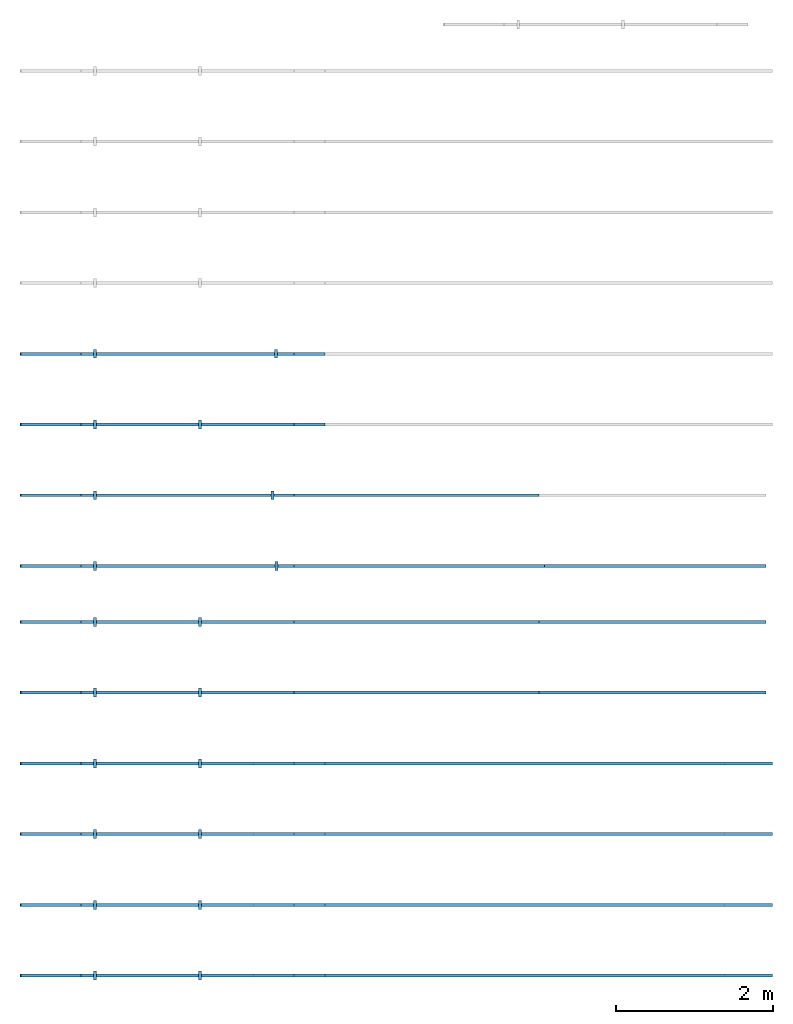
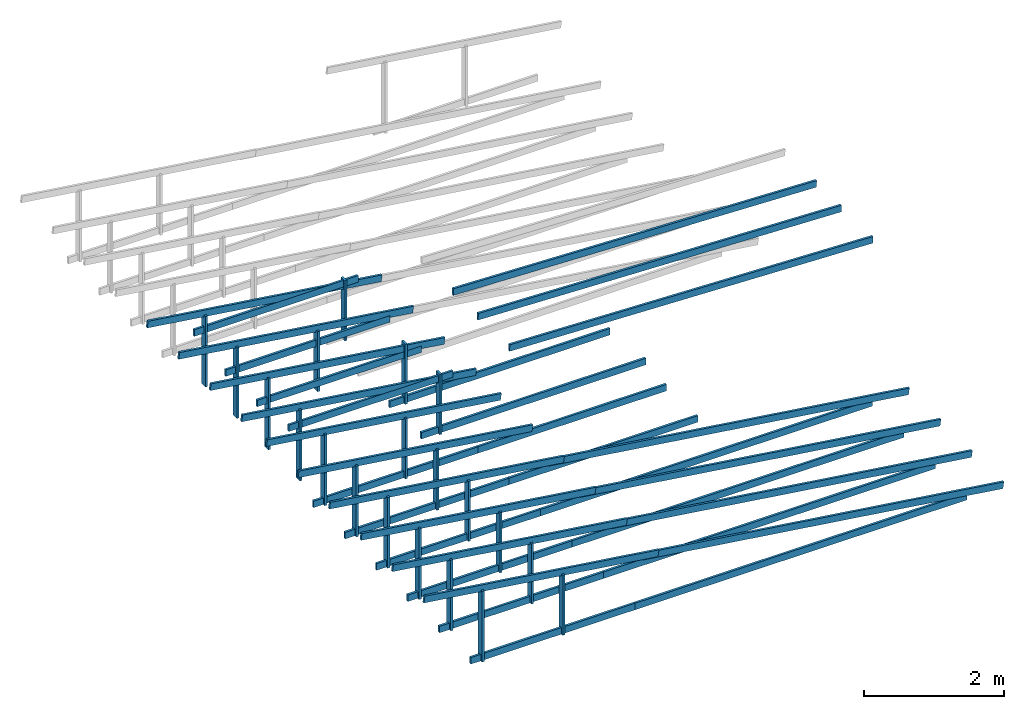
# Not in any storey, part 1 of 2: 55 roofs, 1 element without a shape of its own.
"""IFC4 model written with IfcOpenShell, lengths in millimetres."""

from ifc_helpers import new_model, entity, si_unit, converted_unit, frame, origin_with_axes, origin_2d_with_axis, place, context, subcontext, project, rectangle, extrude, material, material_profile, profile_set, profile_usage, type_object, element, aggregate, save


model = new_model("IFC4")

# Units and contexts
model_context = context("Model", 3, precision=1e-05, world=origin_with_axes())
plan_context = context("Plan", 2, precision=1e-05, world=origin_2d_with_axis())
body_context = subcontext(model_context, "Body", "Model", "MODEL_VIEW")
ifc_project = project(units=[si_unit("VOLUMEUNIT", "CUBIC_METRE"), si_unit("LENGTHUNIT", "METRE", prefix="MILLI"), converted_unit("PLANEANGLEUNIT", "degree", entity("IfcReal", 0.0174532925199433), si_unit("PLANEANGLEUNIT", "RADIAN"), dimensions=[0, 0, 0, 0, 0, 0, 0]), si_unit("AREAUNIT", "SQUARE_METRE")], contexts=[model_context, plan_context])

# Assembly, roofs
assembly_placement = place(None, frame((8638.14163208008, 12731.990814209, 0.0), z_axis=(0.0, 0.0, 1.0), x_axis=(-0.999999999999947, -3.25841369885876e-07, 0.0)))
assembly = element("IfcElementAssembly", 1, at=assembly_placement, Name="Assembly")
ifc_material = material()
ifc_material_profile = material_profile(ifc_material, rectangle(XDim=38.0, YDim=114.0))
ifc_profile_set = profile_set([ifc_material_profile])
ifc_profile_usage_1 = profile_usage(ifc_profile_set, cardinal=5)
roof_type = type_object("IfcRoofType", Name="timber 38x114", PredefinedType="BARREL_ROOF", material=ifc_profile_set)
roof_1_placement = place(assembly_placement, frame((2602.95824585322, 7450.48676552689, 2478.00016403198), z_axis=(0.999999999999919, -3.69552768830747e-07, -1.62920684942944e-07), x_axis=(3.6955275817261e-07, 0.99999999999993, -5.96046376699631e-08)))
roof_1 = element("IfcRoof", 2, at=roof_1_placement, type_object=roof_type, material=ifc_profile_usage_1, Name="Beam.026", PredefinedType="BARREL_ROOF", context=body_context, shape_type="SweptSolid", body=[
    extrude(rectangle(XDim=38.0, YDim=114.0), origin_with_axes(), (0.0, 0.0, 1.0), 3637.04351333381),
])
ifc_profile_usage_2 = profile_usage(ifc_profile_set, cardinal=5)
roof_2_placement = place(assembly_placement, frame((5711.19814191005, 6739.99743333674, 4800.8017539978), z_axis=(-0.999390828302623, -4.9420837146397e-07, -0.034899459943574), x_axis=(4.88762054828645e-07, -0.999999999999867, 1.6459050300449e-07)))
roof_2 = element("IfcRoof", 3, at=roof_2_placement, type_object=roof_type, material=ifc_profile_usage_2, Name="Beam.057", PredefinedType="BARREL_ROOF", context=body_context, shape_type="SweptSolid", body=[
    extrude(rectangle(XDim=38.0, YDim=114.0), origin_with_axes(), (0.0, 0.0, 1.0), 6000.00000000001),
])
ifc_profile_usage_3 = profile_usage(ifc_profile_set, cardinal=5)
roof_3_placement = place(assembly_placement, frame((5719.1305595434, 7450.4862269862, 2478.00016403198), z_axis=(0.999999999999973, 1.62920684942916e-07, -1.62920684942925e-07), x_axis=(-1.62920684942918e-07, 0.999999999999987, 7.1609385088314e-15)))
roof_3 = element("IfcRoof", 4, at=roof_3_placement, type_object=roof_type, material=ifc_profile_usage_3, Name="Beam.063", PredefinedType="BARREL_ROOF", context=body_context, shape_type="SweptSolid", body=[
    extrude(rectangle(XDim=38.0, YDim=114.0), origin_with_axes(), (0.0, 0.0, 1.0), 2709.05258213867),
])
ifc_profile_usage_4 = profile_usage(ifc_profile_set, cardinal=5)
roof_4_placement = place(assembly_placement, frame((8248.028321842, 7450.48587980384, 2420.62544822693), z_axis=(1.05540572307067e-14, 1.20724322982826e-07, 0.999999999999993), x_axis=(-0.999999999999996, 8.74227907843234e-08, -2.09332735654617e-22)))
roof_4 = element("IfcRoof", 5, at=roof_4_placement, type_object=roof_type, material=ifc_profile_usage_4, Name="Beam.085", PredefinedType="BARREL_ROOF", context=body_context, shape_type="SweptSolid", body=[
    extrude(rectangle(XDim=38.0, YDim=114.0), origin_with_axes(), (0.0, 0.0, 1.0), 1234.31299754043),
])
ifc_profile_usage_5 = profile_usage(ifc_profile_set, cardinal=5)
roof_5_placement = place(assembly_placement, frame((5334.54231796627, 7450.48635230096, 3273.04244041443), z_axis=(0.990268086286663, 1.71346197440185e-07, 0.139172976120085), x_axis=(-1.62920684942918e-07, 0.999999999999984, -7.19328738796233e-08)))
roof_5 = element("IfcRoof", 6, at=roof_5_placement, type_object=roof_type, material=ifc_profile_usage_5, Name="Beam.069", PredefinedType="BARREL_ROOF", context=body_context, shape_type="SweptSolid", body=[
    extrude(rectangle(XDim=38.0, YDim=114.0), origin_with_axes(), (0.0, 0.0, 1.0), 3899.99944705231),
])
ifc_profile_usage_6 = profile_usage(ifc_profile_set, cardinal=5)
roof_6_placement = place(assembly_placement, frame((6916.5220695531, 7450.48583682651, 2420.62544822693), z_axis=(1.24156629368653e-14, 1.4201860665253e-07, 0.99999999999999), x_axis=(-0.999999999999996, 8.74227907843234e-08, -7.42746696787314e-22)))
roof_6 = element("IfcRoof", 7, at=roof_6_placement, type_object=roof_type, material=ifc_profile_usage_6, Name="Beam.038", PredefinedType="BARREL_ROOF", context=body_context, shape_type="SweptSolid", body=[
    extrude(rectangle(XDim=38.0, YDim=114.0), origin_with_axes(), (0.0, 0.0, 1.0), 1049.24011663183),
])
ifc_profile_usage_7 = profile_usage(ifc_profile_set, cardinal=5)
roof_7_placement = place(assembly_placement, frame((8248.02861509911, 8350.48549833407, 2420.62544822693), z_axis=(1.05540572307067e-14, 1.20724322982826e-07, 0.999999999999993), x_axis=(-0.999999999999996, 8.74227907843234e-08, -2.09332735654617e-22)))
roof_7 = element("IfcRoof", 8, at=roof_7_placement, type_object=roof_type, material=ifc_profile_usage_7, Name="Beam.017", PredefinedType="BARREL_ROOF", context=body_context, shape_type="SweptSolid", body=[
    extrude(rectangle(XDim=38.0, YDim=114.0), origin_with_axes(), (0.0, 0.0, 1.0), 1234.31299754043),
])
ifc_profile_usage_8 = profile_usage(ifc_profile_set, cardinal=5)
roof_8_placement = place(assembly_placement, frame((2602.95758543601, 8350.48638405743, 2478.00016403198), z_axis=(0.999999999999919, -3.69552768830747e-07, -1.62920684942944e-07), x_axis=(3.6955275817261e-07, 0.99999999999993, -5.96046376699631e-08)))
roof_8 = element("IfcRoof", 9, at=roof_8_placement, type_object=roof_type, material=ifc_profile_usage_8, Name="Beam.056", PredefinedType="BARREL_ROOF", context=body_context, shape_type="SweptSolid", body=[
    extrude(rectangle(XDim=38.0, YDim=114.0), origin_with_axes(), (0.0, 0.0, 1.0), 3637.04443107364),
])
ifc_profile_usage_9 = profile_usage(ifc_profile_set, cardinal=5)
roof_9_placement = place(assembly_placement, frame((5719.13085280051, 8350.48584551642, 2478.00016403198), z_axis=(0.999999999999973, 1.62920684942916e-07, -1.62920684942925e-07), x_axis=(-1.62920684942918e-07, 0.999999999999987, 7.1609385088314e-15)))
roof_9 = element("IfcRoof", 10, at=roof_9_placement, type_object=roof_type, material=ifc_profile_usage_9, Name="Beam.079", PredefinedType="BARREL_ROOF", context=body_context, shape_type="SweptSolid", body=[
    extrude(rectangle(XDim=38.0, YDim=114.0), origin_with_axes(), (0.0, 0.0, 1.0), 2709.05258213867),
])
ifc_profile_usage_10 = profile_usage(ifc_profile_set, cardinal=5)
roof_10_placement = place(assembly_placement, frame((5334.54261122338, 8350.48597083118, 3273.04244041443), z_axis=(0.990268086286663, 1.71346197440185e-07, 0.139172976120085), x_axis=(-1.62920684942918e-07, 0.999999999999984, -7.19328738796233e-08)))
roof_10 = element("IfcRoof", 11, at=roof_10_placement, type_object=roof_type, material=ifc_profile_usage_10, Name="Beam.083", PredefinedType="BARREL_ROOF", context=body_context, shape_type="SweptSolid", body=[
    extrude(rectangle(XDim=38.0, YDim=114.0), origin_with_axes(), (0.0, 0.0, 1.0), 3899.99944705231),
])
ifc_profile_usage_11 = profile_usage(ifc_profile_set, cardinal=5)
roof_11_placement = place(assembly_placement, frame((6916.52236281021, 8350.48545535673, 2420.62544822693), z_axis=(1.24156629368653e-14, 1.4201860665253e-07, 0.99999999999999), x_axis=(-0.999999999999996, 8.74227907843234e-08, -7.42746696787314e-22)))
roof_11 = element("IfcRoof", 12, at=roof_11_placement, type_object=roof_type, material=ifc_profile_usage_11, Name="Beam.002", PredefinedType="BARREL_ROOF", context=body_context, shape_type="SweptSolid", body=[
    extrude(rectangle(XDim=38.0, YDim=114.0), origin_with_axes(), (0.0, 0.0, 1.0), 1049.24011663183),
])
ifc_profile_usage_12 = profile_usage(ifc_profile_set, cardinal=5)
roof_12_placement = place(assembly_placement, frame((5334.54266606191, 9250.48558936149, 3273.04244041443), z_axis=(0.990268086286663, 1.71346197440185e-07, 0.139172976120085), x_axis=(-1.62920684942918e-07, 0.999999999999984, -7.19328738796233e-08)))
roof_12 = element("IfcRoof", 13, at=roof_12_placement, type_object=roof_type, material=ifc_profile_usage_12, Name="Beam.036", PredefinedType="BARREL_ROOF", context=body_context, shape_type="SweptSolid", body=[
    extrude(rectangle(XDim=38.0, YDim=114.0), origin_with_axes(), (0.0, 0.0, 1.0), 3899.99944705231),
])
ifc_profile_usage_13 = profile_usage(ifc_profile_set, cardinal=5)
roof_13_placement = place(assembly_placement, frame((6916.52265606732, 9250.48507388696, 2420.62544822693), z_axis=(1.24156629368653e-14, 1.4201860665253e-07, 0.99999999999999), x_axis=(-0.999999999999996, 8.74227907843234e-08, -7.42746696787314e-22)))
roof_13 = element("IfcRoof", 14, at=roof_13_placement, type_object=roof_type, material=ifc_profile_usage_13, Name="Beam.041", PredefinedType="BARREL_ROOF", context=body_context, shape_type="SweptSolid", body=[
    extrude(rectangle(XDim=38.0, YDim=114.0), origin_with_axes(), (0.0, 0.0, 1.0), 1049.24011663183),
])
ifc_profile_usage_14 = profile_usage(ifc_profile_set, cardinal=5)
roof_14_placement = place(assembly_placement, frame((8248.02890835606, 9250.48464002714, 2420.62544822693), z_axis=(1.05540572307067e-14, 1.20724322982826e-07, 0.999999999999993), x_axis=(-0.999999999999996, 8.74227907843234e-08, -2.09332735654617e-22)))
roof_14 = element("IfcRoof", 15, at=roof_14_placement, type_object=roof_type, material=ifc_profile_usage_14, Name="Beam.047", PredefinedType="BARREL_ROOF", context=body_context, shape_type="SweptSolid", body=[
    extrude(rectangle(XDim=38.0, YDim=114.0), origin_with_axes(), (0.0, 0.0, 1.0), 1234.31299754043),
])
ifc_profile_usage_15 = profile_usage(ifc_profile_set, cardinal=5)
roof_15_placement = place(assembly_placement, frame((-359.997596160236, 9250.48696804113, 2465.76333045959), z_axis=(0.990268068702914, 1.5806549725193e-07, 0.139173101235031), x_axis=(-1.62920684942918e-07, 0.999999999999986, 2.34930119802329e-08)))
roof_15 = element("IfcRoof", 16, at=roof_15_placement, type_object=roof_type, material=ifc_profile_usage_15, Name="Beam.005", PredefinedType="BARREL_ROOF", context=body_context, shape_type="SweptSolid", body=[
    extrude(rectangle(XDim=38.0, YDim=114.0), origin_with_axes(), (0.0, 0.0, 1.0), 6000.00000000001),
])
ifc_profile_usage_16 = profile_usage(ifc_profile_set, cardinal=5)
roof_16_placement = place(assembly_placement, frame((5719.13090763904, 9250.48546404673, 2478.00016403198), z_axis=(0.999999999999973, 1.62920684942916e-07, -1.62920684942925e-07), x_axis=(-1.62920684942918e-07, 0.999999999999987, 7.1609385088314e-15)))
roof_16 = element("IfcRoof", 17, at=roof_16_placement, type_object=roof_type, material=ifc_profile_usage_16, Name="Beam.077", PredefinedType="BARREL_ROOF", context=body_context, shape_type="SweptSolid", body=[
    extrude(rectangle(XDim=38.0, YDim=114.0), origin_with_axes(), (0.0, 0.0, 1.0), 2709.05258213867),
])
ifc_profile_usage_17 = profile_usage(ifc_profile_set, cardinal=5)
roof_17_placement = place(assembly_placement, frame((240.002785309615, 9250.48724937334, 2478.00016403198), z_axis=(0.99999999999995, -3.13916489247373e-07, -4.37113882867379e-08), x_axis=(3.13916489247373e-07, 0.999999999999951, 0.0)))
roof_17 = element("IfcRoof", 18, at=roof_17_placement, type_object=roof_type, material=ifc_profile_usage_17, Name="Beam.082", PredefinedType="BARREL_ROOF", context=body_context, shape_type="SweptSolid", body=[
    extrude(rectangle(XDim=38.0, YDim=114.0), origin_with_axes(), (0.0, 0.0, 1.0), 6000.00000000001),
])
ifc_profile_usage_18 = profile_usage(ifc_profile_set, cardinal=5)
roof_18_placement = place(assembly_placement, frame((5334.54272090044, 10150.4852078918, 3273.04244041443), z_axis=(0.990268086286663, 1.71346197440185e-07, 0.139172976120085), x_axis=(-1.62920684942918e-07, 0.999999999999984, -7.19328738796233e-08)))
roof_18 = element("IfcRoof", 19, at=roof_18_placement, type_object=roof_type, material=ifc_profile_usage_18, Name="Beam.030", PredefinedType="BARREL_ROOF", context=body_context, shape_type="SweptSolid", body=[
    extrude(rectangle(XDim=38.0, YDim=114.0), origin_with_axes(), (0.0, 0.0, 1.0), 3899.99944705231),
])
ifc_profile_usage_19 = profile_usage(ifc_profile_set, cardinal=5)
roof_19_placement = place(assembly_placement, frame((5719.13096247756, 10150.485082577, 2478.00016403198), z_axis=(0.999999999999973, 1.62920684942916e-07, -1.62920684942925e-07), x_axis=(-1.62920684942918e-07, 0.999999999999987, 7.1609385088314e-15)))
roof_19 = element("IfcRoof", 20, at=roof_19_placement, type_object=roof_type, material=ifc_profile_usage_19, Name="Beam.035", PredefinedType="BARREL_ROOF", context=body_context, shape_type="SweptSolid", body=[
    extrude(rectangle(XDim=38.0, YDim=114.0), origin_with_axes(), (0.0, 0.0, 1.0), 2709.05258213867),
])
ifc_profile_usage_20 = profile_usage(ifc_profile_set, cardinal=5)
roof_20_placement = place(assembly_placement, frame((6916.52294932443, 10150.4846924172, 2420.62544822693), z_axis=(1.24156629368653e-14, 1.4201860665253e-07, 0.99999999999999), x_axis=(-0.999999999999996, 8.74227907843234e-08, -7.42746696787314e-22)))
roof_20 = element("IfcRoof", 21, at=roof_20_placement, type_object=roof_type, material=ifc_profile_usage_20, Name="Beam.061", PredefinedType="BARREL_ROOF", context=body_context, shape_type="SweptSolid", body=[
    extrude(rectangle(XDim=38.0, YDim=114.0), origin_with_axes(), (0.0, 0.0, 1.0), 1049.24011663183),
])
ifc_profile_usage_21 = profile_usage(ifc_profile_set, cardinal=5)
roof_21_placement = place(assembly_placement, frame((8248.02920161317, 10150.4842585574, 2420.62544822693), z_axis=(1.05540572307067e-14, 1.20724322982826e-07, 0.999999999999993), x_axis=(-0.999999999999996, 8.74227907843234e-08, -2.09332735654617e-22)))
roof_21 = element("IfcRoof", 22, at=roof_21_placement, type_object=roof_type, material=ifc_profile_usage_21, Name="Beam.066", PredefinedType="BARREL_ROOF", context=body_context, shape_type="SweptSolid", body=[
    extrude(rectangle(XDim=38.0, YDim=114.0), origin_with_axes(), (0.0, 0.0, 1.0), 1234.31299754043),
])
ifc_profile_usage_22 = profile_usage(ifc_profile_set, cardinal=5)
roof_22_placement = place(assembly_placement, frame((-359.997302903126, 10150.4865865714, 2465.76333045959), z_axis=(0.990268068702914, 1.5806549725193e-07, 0.139173101235031), x_axis=(-1.62920684942918e-07, 0.999999999999986, 2.34930119802329e-08)))
roof_22 = element("IfcRoof", 23, at=roof_22_placement, type_object=roof_type, material=ifc_profile_usage_22, Name="Beam.004", PredefinedType="BARREL_ROOF", context=body_context, shape_type="SweptSolid", body=[
    extrude(rectangle(XDim=38.0, YDim=114.0), origin_with_axes(), (0.0, 0.0, 1.0), 6000.00000000001),
])
ifc_profile_usage_23 = profile_usage(ifc_profile_set, cardinal=5)
roof_23_placement = place(assembly_placement, frame((240.003078566723, 10150.4868679036, 2478.00016403198), z_axis=(0.99999999999995, -3.13916489247373e-07, -4.37113882867379e-08), x_axis=(3.13916489247373e-07, 0.999999999999951, 0.0)))
roof_23 = element("IfcRoof", 24, at=roof_23_placement, type_object=roof_type, material=ifc_profile_usage_23, Name="Beam.011", PredefinedType="BARREL_ROOF", context=body_context, shape_type="SweptSolid", body=[
    extrude(rectangle(XDim=38.0, YDim=114.0), origin_with_axes(), (0.0, 0.0, 1.0), 6000.00000000001),
])
ifc_profile_usage_24 = profile_usage(ifc_profile_set, cardinal=5)
roof_24_placement = place(assembly_placement, frame((5334.54301415755, 11050.484826422, 3273.04244041443), z_axis=(0.990268086286663, 1.71346197440185e-07, 0.139172976120085), x_axis=(-1.62920684942918e-07, 0.999999999999984, -7.19328738796233e-08)))
roof_24 = element("IfcRoof", 25, at=roof_24_placement, type_object=roof_type, material=ifc_profile_usage_24, Name="Beam.018", PredefinedType="BARREL_ROOF", context=body_context, shape_type="SweptSolid", body=[
    extrude(rectangle(XDim=38.0, YDim=114.0), origin_with_axes(), (0.0, 0.0, 1.0), 3899.99944705231),
])
ifc_profile_usage_25 = profile_usage(ifc_profile_set, cardinal=5)
roof_25_placement = place(assembly_placement, frame((5719.13125573467, 11050.4847011073, 2478.00016403198), z_axis=(0.999999999999973, 1.62920684942916e-07, -1.62920684942925e-07), x_axis=(-1.62920684942918e-07, 0.999999999999987, 7.1609385088314e-15)))
roof_25 = element("IfcRoof", 26, at=roof_25_placement, type_object=roof_type, material=ifc_profile_usage_25, Name="Beam.049", PredefinedType="BARREL_ROOF", context=body_context, shape_type="SweptSolid", body=[
    extrude(rectangle(XDim=38.0, YDim=114.0), origin_with_axes(), (0.0, 0.0, 1.0), 2709.05258213867),
])
ifc_profile_usage_26 = profile_usage(ifc_profile_set, cardinal=5)
roof_26_placement = place(assembly_placement, frame((240.003371823832, 11050.4864864338, 2478.00016403198), z_axis=(0.99999999999995, -3.13916489247373e-07, -4.37113882867379e-08), x_axis=(3.13916489247373e-07, 0.999999999999951, 0.0)))
roof_26 = element("IfcRoof", 27, at=roof_26_placement, type_object=roof_type, material=ifc_profile_usage_26, Name="Beam.053", PredefinedType="BARREL_ROOF", context=body_context, shape_type="SweptSolid", body=[
    extrude(rectangle(XDim=38.0, YDim=114.0), origin_with_axes(), (0.0, 0.0, 1.0), 6000.00000000001),
])
ifc_profile_usage_27 = profile_usage(ifc_profile_set, cardinal=5)
roof_27_placement = place(assembly_placement, frame((-359.997009645863, 11050.4866819387, 2465.76333045959), z_axis=(0.990268068702914, 1.5806549725193e-07, 0.139173101235031), x_axis=(-1.62920684942918e-07, 0.999999999999986, 2.34930119802329e-08)))
roof_27 = element("IfcRoof", 28, at=roof_27_placement, type_object=roof_type, material=ifc_profile_usage_27, Name="Beam.059", PredefinedType="BARREL_ROOF", context=body_context, shape_type="SweptSolid", body=[
    extrude(rectangle(XDim=38.0, YDim=114.0), origin_with_axes(), (0.0, 0.0, 1.0), 6000.00000000001),
])
ifc_profile_usage_28 = profile_usage(ifc_profile_set, cardinal=5)
roof_28_placement = place(assembly_placement, frame((8248.02901803312, 11050.4838770877, 2420.62544822693), z_axis=(1.05540572307067e-14, 1.20724322982826e-07, 0.999999999999993), x_axis=(-0.999999999999996, 8.74227907843234e-08, -2.09332735654617e-22)))
roof_28 = element("IfcRoof", 29, at=roof_28_placement, type_object=roof_type, material=ifc_profile_usage_28, Name="Beam.065", PredefinedType="BARREL_ROOF", context=body_context, shape_type="SweptSolid", body=[
    extrude(rectangle(XDim=38.0, YDim=114.0), origin_with_axes(), (0.0, 0.0, 1.0), 1234.31299754043),
])
ifc_profile_usage_29 = profile_usage(ifc_profile_set, cardinal=5)
roof_29_placement = place(assembly_placement, frame((6916.52276574437, 11050.4843109476, 2420.62544822693), z_axis=(1.24156629368653e-14, 1.4201860665253e-07, 0.99999999999999), x_axis=(-0.999999999999996, 8.74227907843234e-08, -7.42746696787314e-22)))
roof_29 = element("IfcRoof", 30, at=roof_29_placement, type_object=roof_type, material=ifc_profile_usage_29, Name="Beam.003", PredefinedType="BARREL_ROOF", context=body_context, shape_type="SweptSolid", body=[
    extrude(rectangle(XDim=38.0, YDim=114.0), origin_with_axes(), (0.0, 0.0, 1.0), 1049.24011663183),
])
ifc_profile_usage_30 = profile_usage(ifc_profile_set, cardinal=5)
roof_30_placement = place(assembly_placement, frame((240.003665080939, 11950.486104964, 2478.00016403198), z_axis=(0.99999999999995, -3.13916489247373e-07, -4.37113882867379e-08), x_axis=(3.13916489247373e-07, 0.999999999999951, 0.0)))
roof_30 = element("IfcRoof", 31, at=roof_30_placement, type_object=roof_type, material=ifc_profile_usage_30, Name="Beam.010", PredefinedType="BARREL_ROOF", context=body_context, shape_type="SweptSolid", body=[
    extrude(rectangle(XDim=38.0, YDim=114.0), origin_with_axes(), (0.0, 0.0, 1.0), 6000.00000000001),
])
ifc_profile_usage_31 = profile_usage(ifc_profile_set, cardinal=5)
roof_31_placement = place(assembly_placement, frame((5719.13154899178, 11950.4843196375, 2478.00016403198), z_axis=(0.999999999999973, 1.62920684942916e-07, -1.62920684942925e-07), x_axis=(-1.62920684942918e-07, 0.999999999999987, 7.1609385088314e-15)))
roof_31 = element("IfcRoof", 32, at=roof_31_placement, type_object=roof_type, material=ifc_profile_usage_31, Name="Beam.015", PredefinedType="BARREL_ROOF", context=body_context, shape_type="SweptSolid", body=[
    extrude(rectangle(XDim=38.0, YDim=114.0), origin_with_axes(), (0.0, 0.0, 1.0), 2709.05258213867),
])
ifc_profile_usage_32 = profile_usage(ifc_profile_set, cardinal=5)
roof_32_placement = place(assembly_placement, frame((5334.54330741465, 11950.4844449522, 3273.04244041443), z_axis=(0.990268086286663, 1.71346197440185e-07, 0.139172976120085), x_axis=(-1.62920684942918e-07, 0.999999999999984, -7.19328738796233e-08)))
roof_32 = element("IfcRoof", 33, at=roof_32_placement, type_object=roof_type, material=ifc_profile_usage_32, Name="Beam.068", PredefinedType="BARREL_ROOF", context=body_context, shape_type="SweptSolid", body=[
    extrude(rectangle(XDim=38.0, YDim=114.0), origin_with_axes(), (0.0, 0.0, 1.0), 3899.99944705231),
])
ifc_profile_usage_33 = profile_usage(ifc_profile_set, cardinal=5)
roof_33_placement = place(assembly_placement, frame((-359.996716388755, 11950.486300469, 2465.76333045959), z_axis=(0.990268068702914, 1.5806549725193e-07, 0.139173101235031), x_axis=(-1.62920684942918e-07, 0.999999999999986, 2.34930119802329e-08)))
roof_33 = element("IfcRoof", 34, at=roof_33_placement, type_object=roof_type, material=ifc_profile_usage_33, Name="Beam.072", PredefinedType="BARREL_ROOF", context=body_context, shape_type="SweptSolid", body=[
    extrude(rectangle(XDim=38.0, YDim=114.0), origin_with_axes(), (0.0, 0.0, 1.0), 6000.00000000001),
])
ifc_profile_usage_34 = profile_usage(ifc_profile_set, cardinal=5)
roof_34_placement = place(assembly_placement, frame((8248.02931129023, 11950.483495618, 2420.62544822693), z_axis=(1.05540572307067e-14, 1.20724322982826e-07, 0.999999999999993), x_axis=(-0.999999999999996, 8.74227907843234e-08, -2.09332735654617e-22)))
roof_34 = element("IfcRoof", 35, at=roof_34_placement, type_object=roof_type, material=ifc_profile_usage_34, Name="Beam.078", PredefinedType="BARREL_ROOF", context=body_context, shape_type="SweptSolid", body=[
    extrude(rectangle(XDim=38.0, YDim=114.0), origin_with_axes(), (0.0, 0.0, 1.0), 1234.31299754043),
])
ifc_profile_usage_35 = profile_usage(ifc_profile_set, cardinal=5)
roof_35_placement = place(assembly_placement, frame((6916.52305900148, 11950.4839294778, 2420.62544822693), z_axis=(1.24156629368653e-14, 1.4201860665253e-07, 0.99999999999999), x_axis=(-0.999999999999996, 8.74227907843234e-08, -7.42746696787314e-22)))
roof_35 = element("IfcRoof", 36, at=roof_35_placement, type_object=roof_type, material=ifc_profile_usage_35, Name="Beam.023", PredefinedType="BARREL_ROOF", context=body_context, shape_type="SweptSolid", body=[
    extrude(rectangle(XDim=38.0, YDim=114.0), origin_with_axes(), (0.0, 0.0, 1.0), 1049.24011663183),
])
ifc_profile_usage_36 = profile_usage(ifc_profile_set, cardinal=5)
roof_36_placement = place(assembly_placement, frame((5719.12968668385, 4039.99809832419, 3399.69801902771), z_axis=(0.999999999999973, 1.62920684942916e-07, -1.62920684942925e-07), x_axis=(-1.62920684942918e-07, 0.999999999999987, 7.1609385088314e-15)))
roof_36 = element("IfcRoof", 37, at=roof_36_placement, type_object=roof_type, material=ifc_profile_usage_36, Name="Beam.050", PredefinedType="BARREL_ROOF", context=body_context, shape_type="SweptSolid", body=[
    extrude(rectangle(XDim=38.0, YDim=114.0), origin_with_axes(), (0.0, 0.0, 1.0), 2709.05258213867),
])
ifc_profile_usage_37 = profile_usage(ifc_profile_set, cardinal=5)
roof_37_placement = place(assembly_placement, frame((8248.02721056372, 4039.99727430476, 2420.62544822693), z_axis=(1.05540572307067e-14, 1.20724322982826e-07, 0.999999999999993), x_axis=(-0.999999999999996, 8.74227907843234e-08, -2.09332735654617e-22)))
roof_37 = element("IfcRoof", 38, at=roof_37_placement, type_object=roof_type, material=ifc_profile_usage_37, Name="Beam.016", PredefinedType="BARREL_ROOF", context=body_context, shape_type="SweptSolid", body=[
    extrude(rectangle(XDim=38.0, YDim=114.0), origin_with_axes(), (0.0, 0.0, 1.0), 1234.31299754043),
])
ifc_profile_usage_38 = profile_usage(ifc_profile_set, cardinal=5)
roof_38_placement = place(assembly_placement, frame((5334.54144510672, 4039.99822363895, 3273.04244041443), z_axis=(0.990268086286663, 1.71346197440185e-07, 0.139172976120085), x_axis=(-1.62920684942918e-07, 0.999999999999984, -7.19328738796233e-08)))
roof_38 = element("IfcRoof", 39, at=roof_38_placement, type_object=roof_type, material=ifc_profile_usage_38, Name="Beam.032", PredefinedType="BARREL_ROOF", context=body_context, shape_type="SweptSolid", body=[
    extrude(rectangle(XDim=38.0, YDim=114.0), origin_with_axes(), (0.0, 0.0, 1.0), 3899.99944705231),
])
ifc_profile_usage_39 = profile_usage(ifc_profile_set, cardinal=5)
roof_39_placement = place(assembly_placement, frame((5945.33646616382, 4039.99802461666, 2420.62544822693), z_axis=(1.24156629368653e-14, 1.4201860665253e-07, 0.99999999999999), x_axis=(-0.999999999999996, 8.74227907843234e-08, -7.42746696787314e-22)))
roof_39 = element("IfcRoof", 40, at=roof_39_placement, type_object=roof_type, material=ifc_profile_usage_39, Name="Beam.062", PredefinedType="BARREL_ROOF", context=body_context, shape_type="SweptSolid", body=[
    extrude(rectangle(XDim=38.0, YDim=114.0), origin_with_axes(), (0.0, 0.0, 1.0), 1049.24011663183),
])
ifc_profile_usage_40 = profile_usage(ifc_profile_set, cardinal=5)
roof_40_placement = place(assembly_placement, frame((5334.54149994541, 4939.99831900641, 3273.04244041443), z_axis=(0.990268086286663, 1.71346197440185e-07, 0.139172976120085), x_axis=(-1.62920684942918e-07, 0.999999999999984, -7.19328738796233e-08)))
roof_40 = element("IfcRoof", 41, at=roof_40_placement, type_object=roof_type, material=ifc_profile_usage_40, Name="Beam.009", PredefinedType="BARREL_ROOF", context=body_context, shape_type="SweptSolid", body=[
    extrude(rectangle(XDim=38.0, YDim=114.0), origin_with_axes(), (0.0, 0.0, 1.0), 3899.99944705231),
])
ifc_profile_usage_41 = profile_usage(ifc_profile_set, cardinal=5)
roof_41_placement = place(assembly_placement, frame((5719.12974152254, 4939.99819369165, 3244.92788314819), z_axis=(0.999999999999973, 1.62920684942916e-07, -1.62920684942925e-07), x_axis=(-1.62920684942918e-07, 0.999999999999987, 7.1609385088314e-15)))
roof_41 = element("IfcRoof", 42, at=roof_41_placement, type_object=roof_type, material=ifc_profile_usage_41, Name="Beam.039", PredefinedType="BARREL_ROOF", context=body_context, shape_type="SweptSolid", body=[
    extrude(rectangle(XDim=38.0, YDim=114.0), origin_with_axes(), (0.0, 0.0, 1.0), 2709.05258213867),
])
ifc_profile_usage_42 = profile_usage(ifc_profile_set, cardinal=5)
roof_42_placement = place(assembly_placement, frame((8248.02750382114, 4939.9978465093, 2420.62544822693), z_axis=(1.05540572307067e-14, 1.20724322982826e-07, 0.999999999999993), x_axis=(-0.999999999999996, 8.74227907843234e-08, -2.09332735654617e-22)))
roof_42 = element("IfcRoof", 43, at=roof_42_placement, type_object=roof_type, material=ifc_profile_usage_42, Name="Beam.043", PredefinedType="BARREL_ROOF", context=body_context, shape_type="SweptSolid", body=[
    extrude(rectangle(XDim=38.0, YDim=114.0), origin_with_axes(), (0.0, 0.0, 1.0), 1234.31299754043),
])
ifc_profile_usage_43 = profile_usage(ifc_profile_set, cardinal=5)
roof_43_placement = place(assembly_placement, frame((6916.52125153239, 4939.99828036912, 2420.62544822693), z_axis=(1.24156629368653e-14, 1.4201860665253e-07, 0.99999999999999), x_axis=(-0.999999999999996, 8.74227907843234e-08, -7.42746696787314e-22)))
roof_43 = element("IfcRoof", 44, at=roof_43_placement, type_object=roof_type, material=ifc_profile_usage_43, Name="Beam.075", PredefinedType="BARREL_ROOF", context=body_context, shape_type="SweptSolid", body=[
    extrude(rectangle(XDim=38.0, YDim=114.0), origin_with_axes(), (0.0, 0.0, 1.0), 1049.24011663183),
])
ifc_profile_usage_44 = profile_usage(ifc_profile_set, cardinal=5)
roof_44_placement = place(assembly_placement, frame((5334.54179320267, 5839.9984143738, 3273.04244041443), z_axis=(0.990268086286663, 1.71346197440185e-07, 0.139172976120085), x_axis=(-1.62920684942918e-07, 0.999999999999984, -7.19328738796233e-08)))
roof_44 = element("IfcRoof", 45, at=roof_44_placement, type_object=roof_type, material=ifc_profile_usage_44, Name="Beam.081", PredefinedType="BARREL_ROOF", context=body_context, shape_type="SweptSolid", body=[
    extrude(rectangle(XDim=38.0, YDim=114.0), origin_with_axes(), (0.0, 0.0, 1.0), 3899.99944705231),
])
ifc_profile_usage_45 = profile_usage(ifc_profile_set, cardinal=5)
roof_45_placement = place(assembly_placement, frame((5711.19866667364, 8350.4853712639, 4800.8017539978), z_axis=(-0.999390828302623, -4.9420837146397e-07, -0.034899459943574), x_axis=(4.88762054828645e-07, -0.999999999999867, 1.6459050300449e-07)))
roof_45 = element("IfcRoof", 46, at=roof_45_placement, type_object=roof_type, material=ifc_profile_usage_45, Name="Beam.029", PredefinedType="BARREL_ROOF", context=body_context, shape_type="SweptSolid", body=[
    extrude(rectangle(XDim=38.0, YDim=114.0), origin_with_axes(), (0.0, 0.0, 1.0), 6000.00000000001),
])
ifc_profile_usage_46 = profile_usage(ifc_profile_set, cardinal=5)
roof_46_placement = place(assembly_placement, frame((8248.02779707841, 5839.99794187668, 2420.62544822693), z_axis=(1.05540572307067e-14, 1.20724322982826e-07, 0.999999999999993), x_axis=(-0.999999999999996, 8.74227907843234e-08, -2.09332735654617e-22)))
roof_46 = element("IfcRoof", 47, at=roof_46_placement, type_object=roof_type, material=ifc_profile_usage_46, Name="Beam.054", PredefinedType="BARREL_ROOF", context=body_context, shape_type="SweptSolid", body=[
    extrude(rectangle(XDim=38.0, YDim=114.0), origin_with_axes(), (0.0, 0.0, 1.0), 1234.31299754043),
])
ifc_profile_usage_47 = profile_usage(ifc_profile_set, cardinal=5)
roof_47_placement = place(assembly_placement, frame((2602.95867476394, 5839.99882759942, 2478.00016403198), z_axis=(0.999999999999919, -3.69552767883436e-07, -1.62920680442919e-07), x_axis=(3.6955275817261e-07, 0.99999999999993, -5.96046376699631e-08)))
roof_47 = element("IfcRoof", 48, at=roof_47_placement, type_object=roof_type, material=ifc_profile_usage_47, Name="Beam.037", PredefinedType="BARREL_ROOF", context=body_context, shape_type="SweptSolid", body=[
    extrude(rectangle(XDim=38.0, YDim=114.0), origin_with_axes(), (0.0, 0.0, 1.0), 3637.04233338226),
])
ifc_profile_usage_48 = profile_usage(ifc_profile_set, cardinal=5)
roof_48_placement = place(assembly_placement, frame((5719.1300347798, 5839.99828905904, 3262.07113265991), z_axis=(0.999999999999973, 1.62920684942916e-07, -1.62920684942925e-07), x_axis=(-1.62920684942918e-07, 0.999999999999987, 7.1609385088314e-15)))
roof_48 = element("IfcRoof", 49, at=roof_48_placement, type_object=roof_type, material=ifc_profile_usage_48, Name="Beam.087", PredefinedType="BARREL_ROOF", context=body_context, shape_type="SweptSolid", body=[
    extrude(rectangle(XDim=38.0, YDim=114.0), origin_with_axes(), (0.0, 0.0, 1.0), 2709.05258213867),
])
ifc_profile_usage_49 = profile_usage(ifc_profile_set, cardinal=5)
roof_49_placement = place(assembly_placement, frame((5988.9292672627, 5839.99820114728, 2420.62544822693), z_axis=(1.24156629368653e-14, 1.4201860665253e-07, 0.99999999999999), x_axis=(-0.999999999999996, 8.74227907843234e-08, -7.42746696787314e-22)))
roof_49 = element("IfcRoof", 50, at=roof_49_placement, type_object=roof_type, material=ifc_profile_usage_49, Name="Beam.070", PredefinedType="BARREL_ROOF", context=body_context, shape_type="SweptSolid", body=[
    extrude(rectangle(XDim=38.0, YDim=114.0), origin_with_axes(), (0.0, 0.0, 1.0), 1049.24011663183),
])
ifc_profile_usage_50 = profile_usage(ifc_profile_set, cardinal=5)
roof_50_placement = place(assembly_placement, frame((5334.54208645994, 6739.99850974118, 3273.04244041443), z_axis=(0.990268086286663, 1.71346197440185e-07, 0.139172976120085), x_axis=(-1.62920684942918e-07, 0.999999999999984, -7.19328738796233e-08)))
roof_50 = element("IfcRoof", 51, at=roof_50_placement, type_object=roof_type, material=ifc_profile_usage_50, Name="Beam.074", PredefinedType="BARREL_ROOF", context=body_context, shape_type="SweptSolid", body=[
    extrude(rectangle(XDim=38.0, YDim=114.0), origin_with_axes(), (0.0, 0.0, 1.0), 3899.99944705231),
])
ifc_profile_usage_51 = profile_usage(ifc_profile_set, cardinal=5)
roof_51_placement = place(assembly_placement, frame((5719.13032803707, 6739.99838442642, 3373.78191947937), z_axis=(0.999999999999973, 1.62920684942916e-07, -1.62920684942925e-07), x_axis=(-1.62920684942918e-07, 0.999999999999987, 7.1609385088314e-15)))
roof_51 = element("IfcRoof", 52, at=roof_51_placement, type_object=roof_type, material=ifc_profile_usage_51, Name="Beam.013", PredefinedType="BARREL_ROOF", context=body_context, shape_type="SweptSolid", body=[
    extrude(rectangle(XDim=38.0, YDim=114.0), origin_with_axes(), (0.0, 0.0, 1.0), 2709.05258213867),
])
ifc_profile_usage_52 = profile_usage(ifc_profile_set, cardinal=5)
roof_52_placement = place(assembly_placement, frame((5938.49544797114, 6739.99831294819, 2420.62544822693), z_axis=(1.24156629368653e-14, 1.4201860665253e-07, 0.99999999999999), x_axis=(-0.999999999999996, 8.74227907843234e-08, -7.42746696787314e-22)))
roof_52 = element("IfcRoof", 53, at=roof_52_placement, type_object=roof_type, material=ifc_profile_usage_52, Name="Beam.045", PredefinedType="BARREL_ROOF", context=body_context, shape_type="SweptSolid", body=[
    extrude(rectangle(XDim=38.0, YDim=114.0), origin_with_axes(), (0.0, 0.0, 1.0), 1049.24011663183),
])
ifc_profile_usage_53 = profile_usage(ifc_profile_set, cardinal=5)
roof_53_placement = place(assembly_placement, frame((2531.17304120236, 6739.99894635763, 2478.00016403198), z_axis=(0.999999999999919, -3.69552768830747e-07, -1.62920684942944e-07), x_axis=(3.6955275817261e-07, 0.99999999999993, -5.96046376699631e-08)))
roof_53 = element("IfcRoof", 54, at=roof_53_placement, type_object=roof_type, material=ifc_profile_usage_53, Name="Beam.051", PredefinedType="BARREL_ROOF", context=body_context, shape_type="SweptSolid", body=[
    extrude(rectangle(XDim=38.0, YDim=114.0), origin_with_axes(), (0.0, 0.0, 1.0), 3708.82842512954),
])
ifc_profile_usage_54 = profile_usage(ifc_profile_set, cardinal=5)
roof_54_placement = place(assembly_placement, frame((8248.02809033567, 6739.99803724407, 2420.62544822693), z_axis=(1.05540572307067e-14, 1.20724322982826e-07, 0.999999999999993), x_axis=(-0.999999999999996, 8.74227907843234e-08, -2.09332735654617e-22)))
roof_54 = element("IfcRoof", 55, at=roof_54_placement, type_object=roof_type, material=ifc_profile_usage_54, Name="Beam.058", PredefinedType="BARREL_ROOF", context=body_context, shape_type="SweptSolid", body=[
    extrude(rectangle(XDim=38.0, YDim=114.0), origin_with_axes(), (0.0, 0.0, 1.0), 1234.31299754043),
])
ifc_profile_usage_55 = profile_usage(ifc_profile_set, cardinal=5)
roof_55_placement = place(assembly_placement, frame((5711.19837341638, 7450.48527589651, 4800.8017539978), z_axis=(-0.999390828302623, -4.9420837146397e-07, -0.034899459943574), x_axis=(4.88762054828645e-07, -0.999999999999867, 1.6459050300449e-07)))
roof_55 = element("IfcRoof", 56, at=roof_55_placement, type_object=roof_type, material=ifc_profile_usage_55, Name="Beam.086", PredefinedType="BARREL_ROOF", context=body_context, shape_type="SweptSolid", body=[
    extrude(rectangle(XDim=38.0, YDim=114.0), origin_with_axes(), (0.0, 0.0, 1.0), 6000.00000000001),
])
aggregate(assembly, [roof_1, roof_2, roof_3, roof_4, roof_5, roof_6, roof_7, roof_8, roof_9, roof_10, roof_11, roof_12, roof_13, roof_14, roof_15, roof_16, roof_17, roof_18, roof_19, roof_20, roof_21, roof_22, roof_23, roof_24, roof_25, roof_26, roof_27, roof_28, roof_29, roof_30, roof_31, roof_32, roof_33, roof_34, roof_35, roof_36, roof_37, roof_38, roof_39, roof_40, roof_41, roof_42, roof_43, roof_44, roof_45, roof_46, roof_47, roof_48, roof_49, roof_50, roof_51, roof_52, roof_53, roof_54, roof_55])

save(model, "model.ifc")
